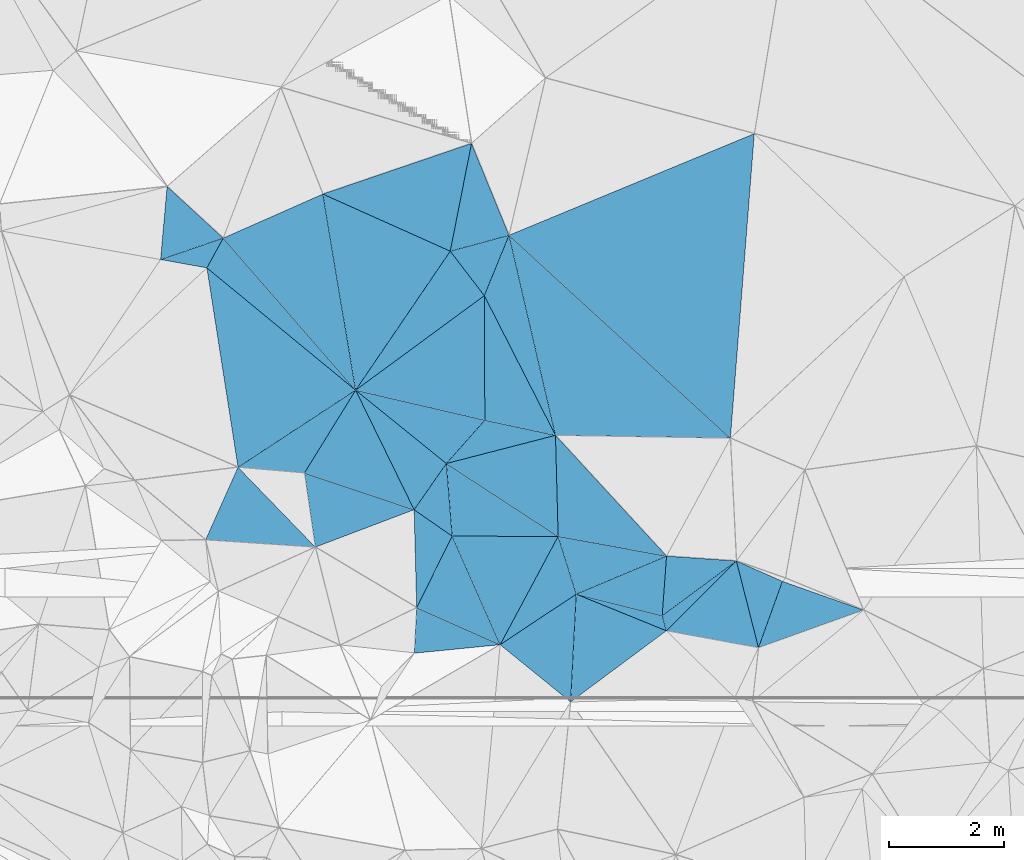
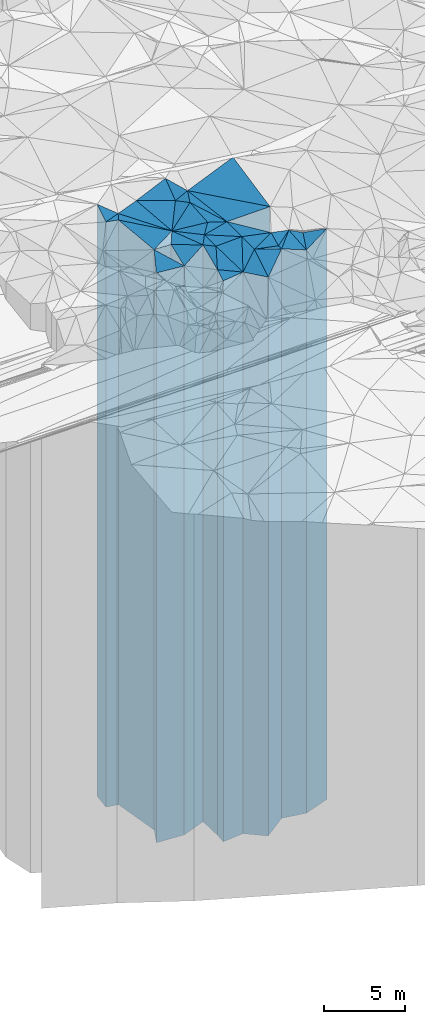
# One storey, part 217 of 275: 41 plates.
"""IFC2X3 building model written with IfcOpenShell, lengths in millimetres."""

import ifcopenshell
import ifcopenshell.guid

model = None  # the IFC model being written
_history = None  # IfcOwnerHistory: only IFC2X3 demands one
_inside = {}  # id of a spatial element -> (the spatial element, [elements in it])
_under = {}  # id of a project, library or spatial element -> (it, [spatial elements below it])
_declared = {}  # id of a project -> (the project, [libraries it declares])
_typed = {}  # id of a type object -> (the type object, [elements of that type])
_made_of = {}  # id of a material, layer set ... -> (it, [elements and type objects made of it])


def new_model(schema):
    """Start an empty IFC model of exactly this schema.

    Asked for "IFC4X3", IfcOpenShell would pick the latest addendum, in which some entities
    have other attributes; the version numbers below select the first issue.
    IFC2X3 requires an IfcOwnerHistory on every rooted entity: one is made here for all.
    """
    global model, _history
    if schema == "IFC4X3":
        model = ifcopenshell.file(schema_version=(4, 3, 0, 0))
    else:
        model = ifcopenshell.file(schema=schema)
    _inside.clear()
    _under.clear()
    _declared.clear()
    _typed.clear()
    _made_of.clear()
    _history = None
    if model.schema == "IFC2X3":
        org = make("IfcOrganization", Name="unknown")
        user = make(
            "IfcPersonAndOrganization",
            ThePerson=make("IfcPerson", FamilyName="unknown"),
            TheOrganization=org,
        )
        app = make(
            "IfcApplication",
            ApplicationDeveloper=org,
            Version="unknown",
            ApplicationFullName="unknown",
            ApplicationIdentifier="unknown",
        )
        _history = make(
            "IfcOwnerHistory",
            OwningUser=user,
            OwningApplication=app,
            ChangeAction="ADDED",
            CreationDate=0,
        )
    return model


def make(cls, **values):
    """One entity of the class cls with the attributes given. An attribute that is None is left unset."""
    return model.create_entity(
        cls, **{name: value for name, value in values.items() if value is not None}
    )


def rooted(cls, **values):
    """An entity with a GlobalId (a new one), such as an element, a storey or a relation."""
    return make(cls, GlobalId=ifcopenshell.guid.new(), OwnerHistory=_history, **values)


def si_unit(unit_type, name, prefix=None):
    """IfcSIUnit, for example si_unit("LENGTHUNIT", "METRE", prefix="MILLI")."""
    return make("IfcSIUnit", UnitType=unit_type, Prefix=prefix, Name=name)


def assignment(units):
    """IfcUnitAssignment: the units of a project."""
    return None if units is None else make("IfcUnitAssignment", Units=units)


def point(xyz):
    """IfcCartesianPoint."""
    return None if xyz is None else make("IfcCartesianPoint", Coordinates=xyz)


def direction(xyz):
    """IfcDirection."""
    return None if xyz is None else make("IfcDirection", DirectionRatios=xyz)


def frame(location, z_axis=None, x_axis=None):
    """IfcAxis2Placement3D, a coordinate frame: its origin and axes. An axis left out is left unset."""
    return make(
        "IfcAxis2Placement3D",
        Location=point(location),
        Axis=direction(z_axis),
        RefDirection=direction(x_axis),
    )


def origin_with_axes():
    """The frame at (0, 0, 0) with the z axis (0, 0, 1) and the x axis (1, 0, 0) written out."""
    return frame((0.0, 0.0, 0.0), z_axis=(0.0, 0.0, 1.0), x_axis=(1.0, 0.0, 0.0))


def place(relative_to, where):
    """IfcLocalPlacement: puts the frame where relative to a parent placement (None: the world)."""
    return make(
        "IfcLocalPlacement", PlacementRelTo=relative_to, RelativePlacement=where
    )


def context(
    kind, dimensions, precision=None, world=None, true_north=None, identifier=None
):
    """IfcGeometricRepresentationContext, for example the 3D "Model" context."""
    return make(
        "IfcGeometricRepresentationContext",
        ContextIdentifier=identifier,
        ContextType=kind,
        CoordinateSpaceDimension=dimensions,
        Precision=precision,
        WorldCoordinateSystem=world,
        TrueNorth=true_north,
    )


def subcontext(parent, identifier, kind, view, scale=None):
    """IfcGeometricRepresentationSubContext, for example "Body" below "Model"."""
    return make(
        "IfcGeometricRepresentationSubContext",
        ContextIdentifier=identifier,
        ContextType=kind,
        ParentContext=parent,
        TargetScale=scale,
        TargetView=view,
    )


def project(units=None, contexts=None):
    """IfcProject with its units and contexts."""
    return rooted(
        "IfcProject",
        Name="project",
        RepresentationContexts=contexts,
        UnitsInContext=assignment(units),
    )


def spatial(cls, under=None, at=None, **own):
    """A site, building, storey or space (cls), placed at a placement, below another one or the project."""
    s = rooted(cls, ObjectPlacement=at, **own)
    if under is not None:
        _under.setdefault(under.id(), (under, []))[1].append(s)
    return s


def faces_of(points, faces, orient=None, outer=None):
    """IfcFace entities. A face is a list of loops; a loop is a list of indices into points, from 0.

    orient and outer hold one flag for each loop. By default every Orientation is true, the
    first loop of a face is its IfcFaceOuterBound and the others are IfcFaceBound.
    """
    made = []
    for i, loops in enumerate(faces):
        bounds = []
        for j, loop in enumerate(loops):
            is_outer = j == 0 if outer is None else outer[i][j]
            bounds.append(
                make(
                    "IfcFaceOuterBound" if is_outer else "IfcFaceBound",
                    Bound=make("IfcPolyLoop", Polygon=[points[k] for k in loop]),
                    Orientation=True if orient is None else orient[i][j],
                )
            )
        made.append(make("IfcFace", Bounds=bounds))
    return made


def faceted_brep(points, faces, orient=None, outer=None, voids=None):
    """IfcFacetedBrep: a solid bounded by flat faces; with voids (closed shells), ...WithVoids."""
    shared = [point(p) for p in points]
    hull = make("IfcClosedShell", CfsFaces=faces_of(shared, faces, orient, outer))
    if voids is None:
        return make("IfcFacetedBrep", Outer=hull)
    return make(
        "IfcFacetedBrepWithVoids",
        Outer=hull,
        Voids=[
            make(cls, CfsFaces=faces_of(shared, fs, o, b)) for cls, fs, o, b in voids
        ],
    )


def shape(context_of_items, identifier, shape_type, items):
    """IfcShapeRepresentation: the items that make up one representation, for example the "Body"."""
    return make(
        "IfcShapeRepresentation",
        ContextOfItems=context_of_items,
        RepresentationIdentifier=identifier,
        RepresentationType=shape_type,
        Items=items,
    )


def material(Name=None, Category=None):
    """IfcMaterial."""
    return make("IfcMaterial", Name=Name, Category=Category)


def made_of(thing, what):
    """Note that an element or type object is made of a material, layer set ...; save() writes the relation."""
    if what is not None:
        _made_of.setdefault(what.id(), (what, []))[1].append(thing)
    return thing


def type_object(cls, material=None, **own):
    """A type object (cls), such as IfcWallType, which elements share."""
    return made_of(rooted(cls, **own), material)


def element(
    cls,
    number,
    at=None,
    inside=None,
    cuts=None,
    type_object=None,
    material=None,
    context=None,
    identifier="Body",
    shape_type=None,
    held_by="IfcProductDefinitionShape",
    body=None,
    shapes=None,
    **own,
):
    """One element of the class cls, such as IfcWall. Its Tag is "e" and its number.

    at: its placement. inside: the storey or other place that contains it. cuts: it is an
    opening in that element (IfcRelVoidsElement). A single representation is given by context,
    identifier, shape_type and body (its items); several are given by shapes. held_by: the class
    of the entity that holds the representations. save() writes the other relations.
    """
    e = rooted(cls, Tag="e%d" % number, ObjectPlacement=at, **own)
    if body is not None:
        shapes = [shape(context, identifier, shape_type, body)]
    if shapes is not None:
        e.Representation = make(held_by, Representations=shapes)
    if inside is not None:
        _inside.setdefault(inside.id(), (inside, []))[1].append(e)
    if cuts is not None:
        rooted(
            "IfcRelVoidsElement", RelatingBuildingElement=cuts, RelatedOpeningElement=e
        )
    if type_object is not None:
        _typed.setdefault(type_object.id(), (type_object, []))[1].append(e)
    return made_of(e, material)


def aggregate(whole, parts):
    """IfcRelAggregates: a whole, such as a stair, and the parts it consists of."""
    return rooted("IfcRelAggregates", RelatingObject=whole, RelatedObjects=parts)


def save(model, path):
    """Write the relations noted so far, then the file.

    IfcRelAggregates (storeys below a building ...), IfcRelContainedInSpatialStructure (elements
    in a storey), IfcRelDefinesByType, IfcRelAssociatesMaterial and IfcRelDeclares: one each for
    every whole, place, type object, material and project.
    """
    for whole, parts in _under.values():
        aggregate(whole, parts)
    for where, things in _inside.values():
        rooted(
            "IfcRelContainedInSpatialStructure",
            RelatedElements=things,
            RelatingStructure=where,
        )
    for kind, things in _typed.values():
        rooted("IfcRelDefinesByType", RelatedObjects=things, RelatingType=kind)
    for what, things in _made_of.values():
        rooted("IfcRelAssociatesMaterial", RelatedObjects=things, RelatingMaterial=what)
    for by, libraries in _declared.values():
        rooted("IfcRelDeclares", RelatingContext=by, RelatedDefinitions=libraries)
    model.write(path)


model = new_model("IFC2X3")

# Units and contexts
model_context = context("Model", 3, precision=1e-05, world=origin_with_axes())
body_context = subcontext(model_context, "Body", "Model", "MODEL_VIEW")
ifc_project = project(units=[si_unit("LENGTHUNIT", "METRE", prefix="MILLI"), si_unit("AREAUNIT", "SQUARE_METRE"), si_unit("VOLUMEUNIT", "CUBIC_METRE"), si_unit("MASSUNIT", "GRAM", prefix="KILO"), si_unit("TIMEUNIT", "SECOND"), si_unit("PLANEANGLEUNIT", "RADIAN"), si_unit("SOLIDANGLEUNIT", "STERADIAN"), si_unit("THERMODYNAMICTEMPERATUREUNIT", "DEGREE_CELSIUS"), si_unit("LUMINOUSINTENSITYUNIT", "LUMEN")], contexts=[model_context])

# Site, building, storey
site_placement = place(None, origin_with_axes())
site = spatial("IfcSite", under=ifc_project, at=site_placement, CompositionType="ELEMENT")
building_placement = place(site_placement, origin_with_axes())
building = spatial("IfcBuilding", under=site, at=building_placement, Name="Undefined", CompositionType="ELEMENT")
storey_placement = place(building_placement, origin_with_axes())
storey = spatial("IfcBuildingStorey", under=building, at=storey_placement, Name="Undefined", CompositionType="ELEMENT", Elevation=0.0)

# Plates
ifc_material = material()
plate_type_1 = type_object("IfcPlateType", PredefinedType="NOTDEFINED")
plate_1_placement = place(storey_placement, frame((-124316.899438529, 68344.4256248502, 28954.0), z_axis=(0.553555277716708, -0.832812436573793, 0.0), x_axis=(-0.832812436573793, -0.553555277716709, 0.0)))
element("IfcPlate", 1, at=plate_1_placement, inside=storey, type_object=plate_type_1, material=ifc_material, Name="00", context=body_context, shape_type="Brep", body=[
    faceted_brep([(1.45519152283669e-11, -22066.0, -1.45519152283669e-11), (1122.43994140628, -21126.0, 1511.63110351561), (1122.43994140628, 21126.0, 1511.63110351561), (1.45519152283669e-11, 21126.0, -1.45519152283669e-11), (1593.04736328126, -21336.0, 5.96628524363041e-10), (1593.04736328126, 21126.0, 5.96628524363041e-10)], [[[0, 1, 2, 3]], [[1, 4, 5, 2]], [[4, 0, 3, 5]], [[5, 3, 2]], [[4, 1, 0]]]),
])
plate_type_2 = type_object("IfcPlateType", PredefinedType="NOTDEFINED")
plate_2_placement = place(storey_placement, frame((-121522.572678423, 68923.9409031251, 29354.0), z_axis=(0.593710242750071, -0.804678909661271, 0.0), x_axis=(-0.804678909661269, -0.593710242750074, 0.0)))
element("IfcPlate", 2, at=plate_2_placement, inside=storey, type_object=plate_type_2, material=ifc_material, Name="00", context=body_context, shape_type="Brep", body=[
    faceted_brep([(3.63797880709171e-11, -21776.0, 0.0), (1706.33032226565, -21526.0, 254.8274078369), (1706.33032226565, 21526.0, 254.8274078369), (3.63797880709171e-11, 21526.0, 0.0), (1608.53967285159, -21626.0, 1.74622982740402e-10), (1608.53967285159, 21526.0, 1.74622982740402e-10)], [[[0, 1, 2, 3]], [[1, 4, 5, 2]], [[4, 0, 3, 5]], [[5, 3, 2]], [[4, 1, 0]]]),
])
plate_type_3 = type_object("IfcPlateType", PredefinedType="NOTDEFINED")
plate_3_placement = place(storey_placement, frame((-119306.686039508, 68066.8257396384, 29124.0), z_axis=(-0.334227246831522, -0.942492518524906, 0.0), x_axis=(-0.942492518524907, 0.33422724683152, 0.0)))
element("IfcPlate", 3, at=plate_3_placement, inside=storey, type_object=plate_type_3, material=ifc_material, Name="00", context=body_context, shape_type="Brep", body=[
    faceted_brep([(0.0, -21866.0, 0.0), (1506.2014160156, -21296.0, 1230.67346191407), (1506.2014160156, 21296.0, 1230.67346191407), (0.0, 21296.0, 0.0), (1499.66662597656, -21766.0, 2.33558239415288e-09), (1499.66662597656, 21296.0, 2.33558239415288e-09)], [[[0, 1, 2, 3]], [[1, 4, 5, 2]], [[4, 0, 3, 5]], [[5, 3, 2]], [[4, 1, 0]]]),
])
plate_type_4 = type_object("IfcPlateType", PredefinedType="NOTDEFINED")
plate_4_placement = place(storey_placement, frame((-122744.327019822, 67705.8209052298, 29124.0), z_axis=(0.180869426929462, 0.983507117616445, 0.0), x_axis=(0.983507117616445, -0.180869426929464, 0.0)))
element("IfcPlate", 4, at=plate_4_placement, inside=storey, type_object=plate_type_4, material=ifc_material, Name="00", context=body_context, shape_type="Brep", body=[
    faceted_brep([(0.0, -21756.0, 0.0), (981.283447265625, -22006.0, 1419.00769042969), (981.283447265625, 21296.0, 1419.00769042969), (0.0, 21296.0, 0.0), (1633.67687988281, -21296.0, -1.25291990116239e-08), (1633.67687988281, 21296.0, -1.25291990116239e-08)], [[[0, 1, 2, 3]], [[1, 4, 5, 2]], [[4, 0, 3, 5]], [[5, 3, 2]], [[4, 1, 0]]]),
])
plate_type_5 = type_object("IfcPlateType", PredefinedType="NOTDEFINED")
plate_5_placement = place(storey_placement, frame((-122740.829133062, 69008.5057346448, 29424.0), z_axis=(-0.179365814947669, -0.983782447712988, 0.0), x_axis=(-0.983782447712987, 0.179365814947674, 0.0)))
element("IfcPlate", 5, at=plate_5_placement, inside=storey, type_object=plate_type_5, material=ifc_material, Name="00", context=body_context, shape_type="Brep", body=[
    faceted_brep([(0.0, -21896.0, -7.27595761418343e-12), (1431.39697265625, -21596.0, 936.003479003899), (1431.39697265625, 21596.0, 936.003479003899), (0.0, 21596.0, -7.27595761418343e-12), (1922.10827636719, -22046.0, -6.3664629124105e-09), (1922.10827636719, 21596.0, -6.3664629124105e-09)], [[[0, 1, 2, 3]], [[1, 4, 5, 2]], [[4, 0, 3, 5]], [[5, 3, 2]], [[4, 1, 0]]]),
])
plate_type_6 = type_object("IfcPlateType", PredefinedType="NOTDEFINED")
plate_6_placement = place(storey_placement, frame((-124316.899438529, 68344.4256248502, 29059.0), z_axis=(-0.954586774630566, -0.297933028884703, 0.0), x_axis=(-0.297933028884702, 0.954586774630566, 0.0)))
element("IfcPlate", 6, at=plate_6_placement, inside=storey, type_object=plate_type_6, material=ifc_material, Name="00", context=body_context, shape_type="Brep", body=[
    faceted_brep([(1.45519152283669e-11, -21961.0, 2.91038304567337e-11), (-446.521972656221, -21231.0, 1529.18872070315), (-446.521972656221, 21231.0, 1529.18872070315), (1.45519152283669e-11, 21231.0, 2.91038304567337e-11), (1056.8348388672, -22411.0, 3.59432306140661e-09), (1056.8348388672, 21231.0, 3.59432306140661e-09)], [[[0, 1, 2, 3]], [[1, 4, 5, 2]], [[4, 0, 3, 5]], [[5, 3, 2]], [[4, 1, 0]]]),
])
plate_type_7 = type_object("IfcPlateType", PredefinedType="NOTDEFINED")
plate_7_placement = place(storey_placement, frame((-125643.609120495, 67462.5858322697, 29059.0), z_axis=(-0.881678049273659, 0.471851478146455, 0.0), x_axis=(0.471851478146456, 0.881678049273659, 0.0)))
element("IfcPlate", 7, at=plate_7_placement, inside=storey, type_object=plate_type_7, material=ifc_material, Name="00", context=body_context, shape_type="Brep", body=[
    faceted_brep([(-7.27595761418343e-12, -21231.0, -2.91038304567337e-11), (1274.19580078124, -22331.0, 1631.35681152347), (1274.19580078124, 21231.0, 1631.35681152347), (1.45519152283669e-11, 21231.0, 2.91038304567337e-11), (2144.41137695312, -22411.0, 1.9121216610074e-08), (2144.41137695312, 21231.0, 1.9121216610074e-08)], [[[0, 1, 2, 3]], [[1, 4, 5, 2]], [[4, 0, 3, 5]], [[5, 3, 2]], [[4, 1, 0]]]),
])
plate_type_8 = type_object("IfcPlateType", PredefinedType="NOTDEFINED")
plate_8_placement = place(storey_placement, frame((-126581.859706102, 70623.1215208211, 29609.0), z_axis=(0.82032191493139, -0.571902050952169, 0.0), x_axis=(-0.571902050952172, -0.820321914931388, 0.0)))
element("IfcPlate", 8, at=plate_8_placement, inside=storey, type_object=plate_type_8, material=ifc_material, Name="00", context=body_context, shape_type="Brep", body=[
    faceted_brep([(-1.63709046319127e-11, -21911.0, 0.0), (981.784545898428, -21781.0, 807.774230957002), (981.784545898428, 21781.0, 807.774230957002), (-1.63709046319127e-11, 21781.0, 0.0), (982.700378417952, -21831.0, -8.32369551062584e-09), (982.700378417952, 21781.0, -8.32369551062584e-09)], [[[0, 1, 2, 3]], [[1, 4, 5, 2]], [[4, 0, 3, 5]], [[5, 3, 2]], [[4, 1, 0]]]),
])
plate_type_9 = type_object("IfcPlateType", PredefinedType="NOTDEFINED")
plate_9_placement = place(storey_placement, frame((-124678.16019158, 71114.9834510479, 29574.0), z_axis=(0.999653415514272, 0.0263258209872142, 0.0), x_axis=(0.0263258209872057, -0.999653415514272, 0.0)))
element("IfcPlate", 9, at=plate_9_placement, inside=storey, type_object=plate_type_9, material=ifc_material, Name="00", context=body_context, shape_type="Brep", body=[
    faceted_brep([(7.27595761418343e-12, -21976.0, -2.91038304567337e-11), (2156.74951171876, -21746.0, 1881.20483398436), (2156.74951171876, 21746.0, 1881.20483398436), (-1.45519152283669e-11, 21746.0, -1.45519152283669e-11), (1762.32800292967, -21896.0, 3.30328475683928e-09), (1762.32800292967, 21746.0, 3.30328475683928e-09)], [[[0, 1, 2, 3]], [[1, 4, 5, 2]], [[4, 0, 3, 5]], [[5, 3, 2]], [[4, 1, 0]]]),
])
plate_type_10 = type_object("IfcPlateType", PredefinedType="NOTDEFINED")
plate_10_placement = place(storey_placement, frame((-124316.899438529, 68344.4256248502, 29404.0), z_axis=(0.242839363030787, 0.970066515122959, 0.0), x_axis=(0.97006651512296, -0.242839363030782, 0.0)))
element("IfcPlate", 10, at=plate_10_placement, inside=storey, type_object=plate_type_10, material=ifc_material, Name="00", context=body_context, shape_type="Brep", body=[
    faceted_brep([(-2.91038304567337e-11, -21616.0, -7.27595761418343e-12), (1367.62829589841, -21916.0, 1026.93383789062), (1367.62829589841, 21576.0, 1026.93383789062), (1.45519152283669e-11, 21576.0, 0.0), (1546.25354003906, -21576.0, -6.3664629124105e-09), (1546.25354003906, 21576.0, -6.3664629124105e-09)], [[[0, 1, 2, 3]], [[1, 4, 5, 2]], [[4, 0, 3, 5]], [[5, 3, 2]], [[4, 1, 0]]]),
])
plate_type_11 = type_object("IfcPlateType", PredefinedType="NOTDEFINED")
plate_11_placement = place(storey_placement, frame((-126480.709404464, 69355.7744426777, 29059.0), z_axis=(0.895759567433081, -0.444538859214918, 0.0), x_axis=(-0.444538859214923, -0.895759567433078, 0.0)))
element("IfcPlate", 11, at=plate_11_placement, inside=storey, type_object=plate_type_11, material=ifc_material, Name="00", context=body_context, shape_type="Brep", body=[
    faceted_brep([(0.0, -22331.0, -2.91038304567337e-11), (1323.71826171876, -21231.0, 1591.43652343747), (1323.71826171876, 21231.0, 1591.43652343747), (1.45519152283669e-11, 21231.0, 2.91038304567337e-11), (1391.76147460938, -21531.0, 5.2677933126688e-09), (1391.76147460938, 21231.0, 5.2677933126688e-09)], [[[0, 1, 2, 3]], [[1, 4, 5, 2]], [[4, 0, 3, 5]], [[5, 3, 2]], [[4, 1, 0]]]),
])
plate_type_12 = type_object("IfcPlateType", PredefinedType="NOTDEFINED")
plate_12_placement = place(storey_placement, frame((-122744.327019822, 67705.8209052298, 29354.0), z_axis=(-0.963973262946218, -0.265999150985154, 0.0), x_axis=(-0.265999150985186, 0.963973262946209, 0.0)))
element("IfcPlate", 12, at=plate_12_placement, inside=storey, type_object=plate_type_12, material=ifc_material, Name="00", context=body_context, shape_type="Brep", body=[
    faceted_brep([(1.45519152283669e-11, -21526.0, 2.91038304567337e-11), (1033.90075683589, -21666.0, 1346.04943847659), (1033.90075683589, 21526.0, 1346.04943847659), (3.63797880709171e-11, 21526.0, 0.0), (272.946868896484, -21626.0, -1.38243194669485e-09), (272.946868896484, 21526.0, -1.38243194669485e-09)], [[[0, 1, 2, 3]], [[1, 4, 5, 2]], [[4, 0, 3, 5]], [[5, 3, 2]], [[4, 1, 0]]]),
])
plate_type_13 = type_object("IfcPlateType", PredefinedType="NOTDEFINED")
plate_13_placement = place(storey_placement, frame((-126480.709404464, 69355.7744426777, 29609.0), z_axis=(0.00135655799982963, 0.999999079874773, 0.0), x_axis=(0.999999079874773, -0.00135655799983099, 0.0)))
element("IfcPlate", 13, at=plate_13_placement, inside=storey, type_object=plate_type_13, material=ifc_material, Name="00", context=body_context, shape_type="Brep", body=[
    faceted_brep([(0.0, -21781.0, -1.45519152283669e-11), (-102.869438171372, -21911.0, 1267.20874023438), (-102.869438171372, 21781.0, 1267.20874023438), (-1.63709046319127e-11, 21781.0, 0.0), (1848.94567871095, -21861.0, -8.68749339133501e-09), (1848.94567871095, 21781.0, -8.68749339133501e-09)], [[[0, 1, 2, 3]], [[1, 4, 5, 2]], [[4, 0, 3, 5]], [[5, 3, 2]], [[4, 1, 0]]]),
])
plate_type_14 = type_object("IfcPlateType", PredefinedType="NOTDEFINED")
plate_14_placement = place(storey_placement, frame((-128164.379958114, 71902.4297917135, 29634.0), z_axis=(0.85074038519691, -0.525586146121654, 0.0), x_axis=(-0.525586146121652, -0.850740385196912, 0.0)))
element("IfcPlate", 14, at=plate_14_placement, inside=storey, type_object=plate_type_14, material=ifc_material, Name="00", context=body_context, shape_type="Brep", body=[
    faceted_brep([(7.27595761418343e-12, -21956.0, 0.0), (1237.80017089844, -21806.0, 1964.26843261719), (1237.80017089844, 21806.0, 1964.26843261719), (7.27595761418343e-12, 21806.0, 0.0), (1697.52758789062, -22116.0, -3.17231751978397e-09), (1697.52758789062, 21806.0, -3.17231751978397e-09)], [[[0, 1, 2, 3]], [[1, 4, 5, 2]], [[4, 0, 3, 5]], [[5, 3, 2]], [[4, 1, 0]]]),
])
plate_type_15 = type_object("IfcPlateType", PredefinedType="NOTDEFINED")
plate_15_placement = place(storey_placement, frame((-127143.868057754, 69816.9908783852, 29634.0), z_axis=(-0.82032191493139, 0.571902050952169, 0.0), x_axis=(0.571902050952172, 0.820321914931388, 0.0)))
element("IfcPlate", 15, at=plate_15_placement, inside=storey, type_object=plate_type_15, material=ifc_material, Name="00", context=body_context, shape_type="Brep", body=[
    faceted_brep([(1.63709046319127e-11, -21806.0, 2.91038304567337e-11), (1127.09838867189, -21956.0, 2029.81506347659), (1127.09838867189, 21806.0, 2029.81506347659), (7.27595761418343e-12, 21806.0, 0.0), (982.700378417985, -21886.0, -8.29459168016911e-09), (982.700378417985, 21806.0, -8.29459168016911e-09)], [[[0, 1, 2, 3]], [[1, 4, 5, 2]], [[4, 0, 3, 5]], [[5, 3, 2]], [[4, 1, 0]]]),
])
plate_type_16 = type_object("IfcPlateType", PredefinedType="NOTDEFINED")
plate_16_placement = place(storey_placement, frame((-128164.379958114, 71902.4297917135, 29709.0), z_axis=(-0.754115668887447, -0.656741621901976, 0.0), x_axis=(-0.656741621901979, 0.754115668887444, 0.0)))
element("IfcPlate", 16, at=plate_16_placement, inside=storey, type_object=plate_type_16, material=ifc_material, Name="00", context=body_context, shape_type="Brep", body=[
    faceted_brep([(-2.91038304567337e-11, -21881.0, 1.45519152283669e-11), (3312.34008789063, -22321.0, 555.430480957039), (3312.34008789063, 21881.0, 555.430480957039), (-2.91038304567337e-11, 21881.0, 1.45519152283669e-11), (3517.27172851563, -22401.0, -2.31375452131033e-09), (3517.27172851563, 21881.0, -2.31375452131033e-09)], [[[0, 1, 2, 3]], [[1, 4, 5, 2]], [[4, 0, 3, 5]], [[5, 3, 2]], [[4, 1, 0]]]),
])
plate_type_17 = type_object("IfcPlateType", PredefinedType="NOTDEFINED")
plate_17_placement = place(storey_placement, frame((-124678.16019158, 71114.9834510479, 29689.0), z_axis=(-0.974068917963009, -0.226251503991407, 0.0), x_axis=(-0.226251503991406, 0.974068917963009, 0.0)))
element("IfcPlate", 17, at=plate_17_placement, inside=storey, type_object=plate_type_17, material=ifc_material, Name="00", context=body_context, shape_type="Brep", body=[
    faceted_brep([(0.0, -21861.0, 0.0), (2653.80346679689, -22261.0, 657.820373535171), (2653.80346679689, 21861.0, 657.820373535171), (0.0, 21861.0, 0.0), (3583.19677734375, -22371.0, -3.97267285734415e-09), (3583.19677734375, 21861.0, -3.97267285734415e-09)], [[[0, 1, 2, 3]], [[1, 4, 5, 2]], [[4, 0, 3, 5]], [[5, 3, 2]], [[4, 1, 0]]]),
])
plate_type_18 = type_object("IfcPlateType", PredefinedType="NOTDEFINED")
plate_18_placement = place(storey_placement, frame((-125919.349595829, 73551.1379746318, 29829.0), z_axis=(-0.925776915633656, 0.378070234850397, 0.0), x_axis=(0.378070234850388, 0.92577691563366, 0.0)))
element("IfcPlate", 18, at=plate_18_placement, inside=storey, type_object=plate_type_18, material=ifc_material, Name="00", context=body_context, shape_type="Brep", body=[
    faceted_brep([(-1.2732925824821e-11, -22121.0, 0.0), (493.483642578125, -22001.0, 843.726196289063), (493.483642578125, 22001.0, 843.726196289063), (1.45519152283669e-11, 22001.0, 0.0), (1138.6395263672, -22231.0, -1.01863406598568e-09), (1138.6395263672, 22001.0, -1.01863406598568e-09)], [[[0, 1, 2, 3]], [[1, 4, 5, 2]], [[4, 0, 3, 5]], [[5, 3, 2]], [[4, 1, 0]]]),
])
plate_type_19 = type_object("IfcPlateType", PredefinedType="NOTDEFINED")
plate_19_placement = place(storey_placement, frame((-126513.880344701, 74326.9815082428, 29829.0), z_axis=(-0.262006675952498, 0.965066060825021, 0.0), x_axis=(0.965066060825021, 0.262006675952499, 0.0)))
element("IfcPlate", 19, at=plate_19_placement, inside=storey, type_object=plate_type_19, material=ifc_material, Name="00", context=body_context, shape_type="Brep", body=[
    faceted_brep([(-2.91038304567337e-11, -22001.0, 1.45519152283669e-11), (850.93920898436, -22421.0, 1717.79003906251), (850.93920898436, 22001.0, 1717.79003906251), (1.45519152283669e-11, 22001.0, 0.0), (1062.12048339841, -22231.0, 2.2846506908536e-09), (1062.12048339841, 22001.0, 2.2846506908536e-09)], [[[0, 1, 2, 3]], [[1, 4, 5, 2]], [[4, 0, 3, 5]], [[5, 3, 2]], [[4, 1, 0]]]),
])
plate_type_20 = type_object("IfcPlateType", PredefinedType="NOTDEFINED")
plate_20_placement = place(storey_placement, frame((-121209.85697089, 76377.0146909164, 29739.0), z_axis=(0.38255954606827, -0.92393083816487, 0.0), x_axis=(-0.923930838164872, -0.382559546068265, 0.0)))
element("IfcPlate", 20, at=plate_20_placement, inside=storey, type_object=plate_type_20, material=ifc_material, Name="00", context=body_context, shape_type="Brep", body=[
    faceted_brep([(-1.45519152283669e-11, -22281.0, 0.0), (2417.89233398439, -21911.0, 4748.76806640622), (2417.89233398439, 21911.0, 4748.76806640622), (0.0, 21911.0, -2.91038304567337e-11), (4631.30664062499, -22321.0, -1.55851012095809e-08), (4631.30664062499, 21911.0, -1.55851012095809e-08)], [[[0, 1, 2, 3]], [[1, 4, 5, 2]], [[4, 0, 3, 5]], [[5, 3, 2]], [[4, 1, 0]]]),
])
plate_type_21 = type_object("IfcPlateType", PredefinedType="NOTDEFINED")
plate_21_placement = place(storey_placement, frame((-128164.379958114, 71902.4297917135, 29709.0), z_axis=(-0.826640325419332, 0.562730639285459, 0.0), x_axis=(0.562730639285457, 0.826640325419333, 0.0)))
element("IfcPlate", 21, at=plate_21_placement, inside=storey, type_object=plate_type_21, material=ifc_material, Name="00", context=body_context, shape_type="Brep", body=[
    faceted_brep([(-2.91038304567337e-11, -21881.0, 1.45519152283669e-11), (2505.74584960934, -22301.0, 2398.00708007813), (2505.74584960934, 21881.0, 2398.00708007813), (-2.91038304567337e-11, 21881.0, 1.45519152283669e-11), (2933.01904296873, -22121.0, -1.83354131877422e-09), (2933.01904296873, 21881.0, -1.83354131877422e-09)], [[[0, 1, 2, 3]], [[1, 4, 5, 2]], [[4, 0, 3, 5]], [[5, 3, 2]], [[4, 1, 0]]]),
])
plate_type_22 = type_object("IfcPlateType", PredefinedType="NOTDEFINED")
plate_22_placement = place(storey_placement, frame((-124678.16019158, 71114.9834510479, 29689.0), z_axis=(0.0165461689962763, 0.999863102775348, 0.0), x_axis=(0.999863102775348, -0.016546168996281, 0.0)))
element("IfcPlate", 22, at=plate_22_placement, inside=storey, type_object=plate_type_22, material=ifc_material, Name="00", context=body_context, shape_type="Brep", body=[
    faceted_brep([(0.0, -21861.0, 0.0), (-868.34350585939, -22371.0, 3476.38891601565), (-868.34350585939, 21861.0, 3476.38891601565), (0.0, 21861.0, 0.0), (3051.44238281247, -21961.0, -1.72003637999296e-08), (3051.44238281247, 21861.0, -1.72003637999296e-08)], [[[0, 1, 2, 3]], [[1, 4, 5, 2]], [[4, 0, 3, 5]], [[5, 3, 2]], [[4, 1, 0]]]),
])
plate_type_23 = type_object("IfcPlateType", PredefinedType="NOTDEFINED")
plate_23_placement = place(storey_placement, frame((-126142.740235707, 76207.7140834634, 29829.0), z_axis=(0.32274850884282, -0.946484759539073, 0.0), x_axis=(-0.946484759539072, -0.322748508842823, 0.0)))
element("IfcPlate", 23, at=plate_23_placement, inside=storey, type_object=plate_type_23, material=ifc_material, Name="00", context=body_context, shape_type="Brep", body=[
    faceted_brep([(-1.45519152283669e-11, -22421.0, -2.91038304567337e-11), (958.282104492173, -22001.0, 1660.29980468751), (958.282104492173, 22001.0, 1660.29980468751), (1.45519152283669e-11, 22001.0, 0.0), (2740.52905273438, -22181.0, 8.55652615427971e-09), (2740.52905273438, 22001.0, 8.55652615427971e-09)], [[[0, 1, 2, 3]], [[1, 4, 5, 2]], [[4, 0, 3, 5]], [[5, 3, 2]], [[4, 1, 0]]]),
])
plate_type_24 = type_object("IfcPlateType", PredefinedType="NOTDEFINED")
plate_24_placement = place(storey_placement, frame((-131566.529735566, 74181.2621444283, 29929.0), z_axis=(0.177495184991706, 0.984121668953976, 0.0), x_axis=(0.984121668953977, -0.177495184991705, 0.0)))
element("IfcPlate", 24, at=plate_24_placement, inside=storey, type_object=plate_type_24, material=ifc_material, Name="00", context=body_context, shape_type="Brep", body=[
    faceted_brep([(0.0, -22151.0, 1.45519152283669e-11), (1008.5568847656, -22181.0, 561.527404785149), (1008.5568847656, 22101.0, 561.527404785149), (0.0, 22101.0, -7.27595761418343e-12), (820.975036621094, -22101.0, 3.688910510391e-09), (820.975036621094, 22101.0, 3.688910510391e-09)], [[[0, 1, 2, 3]], [[1, 4, 5, 2]], [[4, 0, 3, 5]], [[5, 3, 2]], [[4, 1, 0]]]),
])
plate_type_25 = type_object("IfcPlateType", PredefinedType="NOTDEFINED")
plate_25_placement = place(storey_placement, frame((-130758.590418801, 74035.5430296028, 29709.0), z_axis=(0.988042209599828, 0.15418363093756, 0.0), x_axis=(0.154183630937555, -0.988042209599829, 0.0)))
element("IfcPlate", 25, at=plate_25_placement, inside=storey, type_object=plate_type_25, material=ifc_material, Name="00", context=body_context, shape_type="Brep", body=[
    faceted_brep([(0.0, -22321.0, 0.0), (2507.59082031251, -21881.0, 2234.29833984375), (2507.59082031251, 21881.0, 2234.29833984375), (-2.91038304567337e-11, 21881.0, 1.45519152283669e-11), (3519.67333984374, -22001.0, 2.04745447263122e-08), (3519.67333984374, 21881.0, 2.04745447263122e-08)], [[[0, 1, 2, 3]], [[1, 4, 5, 2]], [[4, 0, 3, 5]], [[5, 3, 2]], [[4, 1, 0]]]),
])
plate_type_26 = type_object("IfcPlateType", PredefinedType="NOTDEFINED")
plate_26_placement = place(storey_placement, frame((-128736.609305546, 75323.212388421, 29709.0), z_axis=(0.404396271985505, -0.914583869967225, 0.0), x_axis=(-0.914583869967225, -0.404396271985505, 0.0)))
element("IfcPlate", 26, at=plate_26_placement, inside=storey, type_object=plate_type_26, material=ifc_material, Name="00", context=body_context, shape_type="Brep", body=[
    faceted_brep([(0.0, -22301.0, -1.09139364212751e-11), (860.000000000015, -21881.0, 3360.0), (860.000000000015, 21881.0, 3360.0), (-2.91038304567337e-11, 21881.0, 1.45519152283669e-11), (1900.00000000001, -22401.0, -1.11176632344723e-08), (1900.00000000001, 21881.0, -1.11176632344723e-08)], [[[0, 1, 2, 3]], [[1, 4, 5, 2]], [[4, 0, 3, 5]], [[5, 3, 2]], [[4, 1, 0]]]),
])
plate_type_27 = type_object("IfcPlateType", PredefinedType="NOTDEFINED")
plate_27_placement = place(storey_placement, frame((-122740.829133062, 69008.5057346448, 29404.0), z_axis=(0.997331256089752, -0.0730093530065712, 0.0), x_axis=(-0.0730093530065727, -0.997331256089752, 0.0)))
element("IfcPlate", 27, at=plate_27_placement, inside=storey, type_object=plate_type_27, material=ifc_material, Name="00", context=body_context, shape_type="Brep", body=[
    faceted_brep([(0.0, -21916.0, 1.45519152283669e-11), (-4.60496520996821, -21726.0, 1221.17932128905), (-4.60496520996821, 21576.0, 1221.17932128905), (1.45519152283669e-11, 21576.0, 0.0), (1042.35314941407, -21576.0, -4.16184775531292e-09), (1042.35314941407, 21576.0, -4.16184775531292e-09)], [[[0, 1, 2, 3]], [[1, 4, 5, 2]], [[4, 0, 3, 5]], [[5, 3, 2]], [[4, 1, 0]]]),
])
plate_type_28 = type_object("IfcPlateType", PredefinedType="NOTDEFINED")
plate_28_placement = place(storey_placement, frame((-125919.349595829, 73551.1379746318, 29689.0), z_axis=(0.999991297954456, 0.00417181199981053, 0.0), x_axis=(0.00417181199981296, -0.999991297954456, 0.0)))
element("IfcPlate", 28, at=plate_28_placement, inside=storey, type_object=plate_type_28, material=ifc_material, Name="00", context=body_context, shape_type="Brep", body=[
    faceted_brep([(0.0, -22261.0, 1.45519152283669e-11), (2441.31127929686, -21861.0, 1231.01538085938), (2441.31127929686, 21861.0, 1231.01538085938), (0.0, 21861.0, 0.0), (2171.86547851561, -22081.0, 1.08993845060468e-08), (2171.86547851561, 21861.0, 1.08993845060468e-08)], [[[0, 1, 2, 3]], [[1, 4, 5, 2]], [[4, 0, 3, 5]], [[5, 3, 2]], [[4, 1, 0]]]),
])
plate_type_29 = type_object("IfcPlateType", PredefinedType="NOTDEFINED")
plate_29_placement = place(storey_placement, frame((-126480.709404464, 69355.7744426777, 29209.0), z_axis=(-0.570971612917301, -0.82096980288109, 0.0), x_axis=(-0.820969802881091, 0.5709716129173, 0.0)))
element("IfcPlate", 29, at=plate_29_placement, inside=storey, type_object=plate_type_29, material=ifc_material, Name="00", context=body_context, shape_type="Brep", body=[
    faceted_brep([(0.0, -22181.0, 0.0), (-203.893478393526, -21381.0, 1376.74523925783), (-203.893478393526, 21381.0, 1376.74523925783), (2.91038304567337e-11, 21381.0, 1.63709046319127e-11), (807.77471923831, -22231.0, -2.82852852251381e-09), (807.77471923831, 21381.0, -2.82852852251381e-09)], [[[0, 1, 2, 3]], [[1, 4, 5, 2]], [[4, 0, 3, 5]], [[5, 3, 2]], [[4, 1, 0]]]),
])
plate_type_30 = type_object("IfcPlateType", PredefinedType="NOTDEFINED")
plate_30_placement = place(storey_placement, frame((-128164.379958114, 71902.4297917135, 29709.0), z_axis=(0.226075315088855, 0.974109825382885, 0.0), x_axis=(0.974109825382884, -0.22607531508886, 0.0)))
element("IfcPlate", 30, at=plate_30_placement, inside=storey, type_object=plate_type_30, material=ifc_material, Name="00", context=body_context, shape_type="Brep", body=[
    faceted_brep([(-2.91038304567337e-11, -21881.0, 1.45519152283669e-11), (1814.17395019531, -22241.0, 2113.56884765626), (1814.17395019531, 21881.0, 2113.56884765626), (-2.91038304567337e-11, 21881.0, 1.45519152283669e-11), (2314.0009765625, -22061.0, -1.74695742316544e-08), (2314.0009765625, 21881.0, -1.74695742316544e-08)], [[[0, 1, 2, 3]], [[1, 4, 5, 2]], [[4, 0, 3, 5]], [[5, 3, 2]], [[4, 1, 0]]]),
])
plate_type_31 = type_object("IfcPlateType", PredefinedType="NOTDEFINED")
plate_31_placement = place(storey_placement, frame((-128164.379958114, 71902.4297917135, 29709.0), z_axis=(0.548130010920778, -0.836393143879114, 0.0), x_axis=(-0.836393143879114, -0.548130010920778, 0.0)))
element("IfcPlate", 31, at=plate_31_placement, inside=storey, type_object=plate_type_31, material=ifc_material, Name="00", context=body_context, shape_type="Brep", body=[
    faceted_brep([(-2.91038304567337e-11, -21881.0, 1.45519152283669e-11), (1537.81225585939, -22041.0, 718.841613769546), (1537.81225585939, 21881.0, 718.841613769546), (-2.91038304567337e-11, 21881.0, 1.45519152283669e-11), (2452.83520507813, -22001.0, 9.35688149183989e-09), (2452.83520507813, 21881.0, 9.35688149183989e-09)], [[[0, 1, 2, 3]], [[1, 4, 5, 2]], [[4, 0, 3, 5]], [[5, 3, 2]], [[4, 1, 0]]]),
])
plate_type_32 = type_object("IfcPlateType", PredefinedType="NOTDEFINED")
plate_32_placement = place(storey_placement, frame((-125919.349595829, 73551.1379746318, 29709.0), z_axis=(-0.793745957012828, -0.608249419009825, 0.0), x_axis=(-0.608249419009825, 0.793745957012829, 0.0)))
element("IfcPlate", 32, at=plate_32_placement, inside=storey, type_object=plate_type_32, material=ifc_material, Name="00", context=body_context, shape_type="Brep", body=[
    faceted_brep([(-2.91038304567337e-11, -22241.0, 3.63797880709171e-11), (56.8829574584961, -21881.0, 2784.80957031251), (56.8829574584961, 21881.0, 2784.80957031251), (-2.91038304567337e-11, 21881.0, 1.45519152283669e-11), (977.445678710938, -22121.0, 1.33150024339557e-09), (977.445678710938, 21881.0, 1.33150024339557e-09)], [[[0, 1, 2, 3]], [[1, 4, 5, 2]], [[4, 0, 3, 5]], [[5, 3, 2]], [[4, 1, 0]]]),
])
plate_type_33 = type_object("IfcPlateType", PredefinedType="NOTDEFINED")
plate_33_placement = place(storey_placement, frame((-121137.59422499, 67410.3387128543, 29124.0), z_axis=(-0.940704534975455, 0.339227029991144, 0.0), x_axis=(0.339227029991153, 0.940704534975452, 0.0)))
element("IfcPlate", 33, at=plate_33_placement, inside=storey, type_object=plate_type_33, material=ifc_material, Name="00", context=body_context, shape_type="Brep", body=[
    faceted_brep([(0.0, -21296.0, 1.45519152283669e-11), (1293.25732421876, -22006.0, 875.605773925781), (1293.25732421876, 21296.0, 875.605773925781), (0.0, 21296.0, 0.0), (1230.69091796876, -21766.0, -3.49245965480804e-10), (1230.69091796876, 21296.0, -3.49245965480804e-10)], [[[0, 1, 2, 3]], [[1, 4, 5, 2]], [[4, 0, 3, 5]], [[5, 3, 2]], [[4, 1, 0]]]),
])
plate_type_34 = type_object("IfcPlateType", PredefinedType="NOTDEFINED")
plate_34_placement = place(storey_placement, frame((-126581.859706102, 70623.1215208211, 29674.0), z_axis=(-0.747694121863929, 0.664043296879148, 0.0), x_axis=(0.664043296879145, 0.747694121863932, 0.0)))
element("IfcPlate", 34, at=plate_34_placement, inside=storey, type_object=plate_type_34, material=ifc_material, Name="00", context=body_context, shape_type="Brep", body=[
    faceted_brep([(-7.27595761418343e-12, -21846.0, -2.91038304567337e-11), (-94.3306884765771, -21916.0, 2032.75720214847), (-94.3306884765771, 21846.0, 2032.75720214847), (-7.27595761418343e-12, 21846.0, 2.91038304567337e-11), (1011.33575439451, -22096.0, -1.39698386192322e-09), (1011.33575439451, 21846.0, -1.39698386192322e-09)], [[[0, 1, 2, 3]], [[1, 4, 5, 2]], [[4, 0, 3, 5]], [[5, 3, 2]], [[4, 1, 0]]]),
])
plate_type_35 = type_object("IfcPlateType", PredefinedType="NOTDEFINED")
plate_35_placement = place(storey_placement, frame((-130474.318658095, 74554.8594707682, 29954.0), z_axis=(-0.677714579384566, -0.735325063417262, 0.0), x_axis=(-0.735325063417259, 0.67771457938457, 0.0)))
element("IfcPlate", 35, at=plate_35_placement, inside=storey, type_object=plate_type_35, material=ifc_material, Name="00", context=body_context, shape_type="Brep", body=[
    faceted_brep([(0.0, -22156.0, 2.91038304567337e-11), (549.937805175781, -22126.0, 1014.92285156249), (549.937805175781, 22126.0, 1014.92285156249), (0.0, 22126.0, 1.45519152283669e-11), (1330.150390625, -22646.0, 9.78616299107671e-09), (1330.150390625, 22126.0, 9.78616299107671e-09)], [[[0, 1, 2, 3]], [[1, 4, 5, 2]], [[4, 0, 3, 5]], [[5, 3, 2]], [[4, 1, 0]]]),
])
plate_type_36 = type_object("IfcPlateType", PredefinedType="NOTDEFINED")
plate_36_placement = place(storey_placement, frame((-124414.909990113, 66464.1878920679, 28954.0), z_axis=(-0.596518566935384, 0.802599276913053, 0.0), x_axis=(0.802599276913057, 0.596518566935379, 0.0)))
element("IfcPlate", 36, at=plate_36_placement, inside=storey, type_object=plate_type_36, material=ifc_material, Name="00", context=body_context, shape_type="Brep", body=[
    faceted_brep([(7.27595761418343e-12, -21126.0, 0.0), (1200.25988769532, -22066.0, 1450.6123046875), (1200.25988769532, 21126.0, 1450.6123046875), (1.45519152283669e-11, 21126.0, -1.45519152283669e-11), (2081.4658203125, -21926.0, -5.89352566748858e-09), (2081.4658203125, 21126.0, -5.89352566748858e-09)], [[[0, 1, 2, 3]], [[1, 4, 5, 2]], [[4, 0, 3, 5]], [[5, 3, 2]], [[4, 1, 0]]]),
])
plate_type_37 = type_object("IfcPlateType", PredefinedType="NOTDEFINED")
plate_37_placement = place(storey_placement, frame((-124631.765460229, 69353.2662407945, 29649.0), z_axis=(-0.999653415514272, -0.0263258209872142, 0.0), x_axis=(-0.0263258209872052, 0.999653415514272, 0.0)))
element("IfcPlate", 37, at=plate_37_placement, inside=storey, type_object=plate_type_37, material=ifc_material, Name="00", context=body_context, shape_type="Brep", body=[
    faceted_brep([(0.0, -21821.0, 0.0), (1320.75305175784, -21871.0, 1915.98840332034), (1320.75305175784, 21821.0, 1915.98840332034), (0.0, 21821.0, 2.91038304567337e-11), (1762.3280029297, -21901.0, 3.34694050252438e-09), (1762.3280029297, 21821.0, 3.34694050252438e-09)], [[[0, 1, 2, 3]], [[1, 4, 5, 2]], [[4, 0, 3, 5]], [[5, 3, 2]], [[4, 1, 0]]]),
])
plate_type_38 = type_object("IfcPlateType", PredefinedType="NOTDEFINED")
plate_38_placement = place(storey_placement, frame((-124678.16019158, 71114.9834510479, 29674.0), z_axis=(-0.209741726907816, -0.977756824570265, 0.0), x_axis=(-0.977756824570265, 0.209741726907815, 0.0)))
element("IfcPlate", 38, at=plate_38_placement, inside=storey, type_object=plate_type_38, material=ifc_material, Name="00", context=body_context, shape_type="Brep", body=[
    faceted_brep([(2.91038304567337e-11, -21876.0, -7.27595761418343e-12), (1758.1911621094, -21846.0, 880.206604003906), (1758.1911621094, 21846.0, 880.206604003906), (-7.27595761418343e-12, 21846.0, 2.91038304567337e-11), (1260.15869140628, -22096.0, 1.70257408171892e-09), (1260.15869140628, 21846.0, 1.70257408171892e-09)], [[[0, 1, 2, 3]], [[1, 4, 5, 2]], [[4, 0, 3, 5]], [[5, 3, 2]], [[4, 1, 0]]]),
])
plate_type_39 = type_object("IfcPlateType", PredefinedType="NOTDEFINED")
plate_39_placement = place(storey_placement, frame((-127143.868057754, 69816.9908783852, 29339.0), z_axis=(-0.317884202901632, -0.948129544706626, 0.0), x_axis=(-0.948129544706625, 0.317884202901635, 0.0)))
element("IfcPlate", 39, at=plate_39_placement, inside=storey, type_object=plate_type_39, material=ifc_material, Name="00", context=body_context, shape_type="Brep", body=[
    faceted_brep([(0.0, -22101.0, -1.45519152283669e-11), (1426.42590332031, -21511.0, 1166.580078125), (1426.42590332031, 21511.0, 1166.580078125), (0.0, 21511.0, -1.45519152283669e-11), (2017.34973144531, -22411.0, 1.64800439961255e-09), (2017.34973144531, 21511.0, 1.64800439961255e-09)], [[[0, 1, 2, 3]], [[1, 4, 5, 2]], [[4, 0, 3, 5]], [[5, 3, 2]], [[4, 1, 0]]]),
])
plate_type_40 = type_object("IfcPlateType", PredefinedType="NOTDEFINED")
plate_40_placement = place(storey_placement, frame((-130215.914413959, 70557.9572644823, 29339.0), z_axis=(0.913066207167866, -0.407811355074975, 0.0), x_axis=(-0.407811355074977, -0.913066207167865, 0.0)))
element("IfcPlate", 40, at=plate_40_placement, inside=storey, type_object=plate_type_40, material=ifc_material, Name="00", context=body_context, shape_type="Brep", body=[
    faceted_brep([(0.0, -22371.0, -1.45519152283669e-11), (722.401733398438, -21511.0, 1799.84326171875), (722.401733398438, 21511.0, 1799.84326171875), (0.0, 21511.0, -1.45519152283669e-11), (1387.73193359374, -21581.0, -7.42147676646709e-09), (1387.73193359374, 21511.0, -7.42147676646709e-09)], [[[0, 1, 2, 3]], [[1, 4, 5, 2]], [[4, 0, 3, 5]], [[5, 3, 2]], [[4, 1, 0]]]),
])
plate_type_41 = type_object("IfcPlateType", PredefinedType="NOTDEFINED")
plate_41_placement = place(storey_placement, frame((-125643.609120495, 67462.5858322697, 29034.0), z_axis=(-0.405869062076047, -0.91393123617125, 0.0), x_axis=(-0.913931236171249, 0.40586906207605, 0.0)))
element("IfcPlate", 41, at=plate_41_placement, inside=storey, type_object=plate_type_41, material=ifc_material, Name="00", context=body_context, shape_type="Brep", body=[
    faceted_brep([(0.0, -21256.0, 0.0), (1308.7529296875, -21206.0, 743.616760253921), (1308.7529296875, 21206.0, 743.616760253921), (-1.45519152283669e-11, 21206.0, 0.0), (1592.89050292969, -21556.0, 5.3114490583539e-10), (1592.89050292969, 21206.0, 5.3114490583539e-10)], [[[0, 1, 2, 3]], [[1, 4, 5, 2]], [[4, 0, 3, 5]], [[5, 3, 2]], [[4, 1, 0]]]),
])

save(model, "model.ifc")
